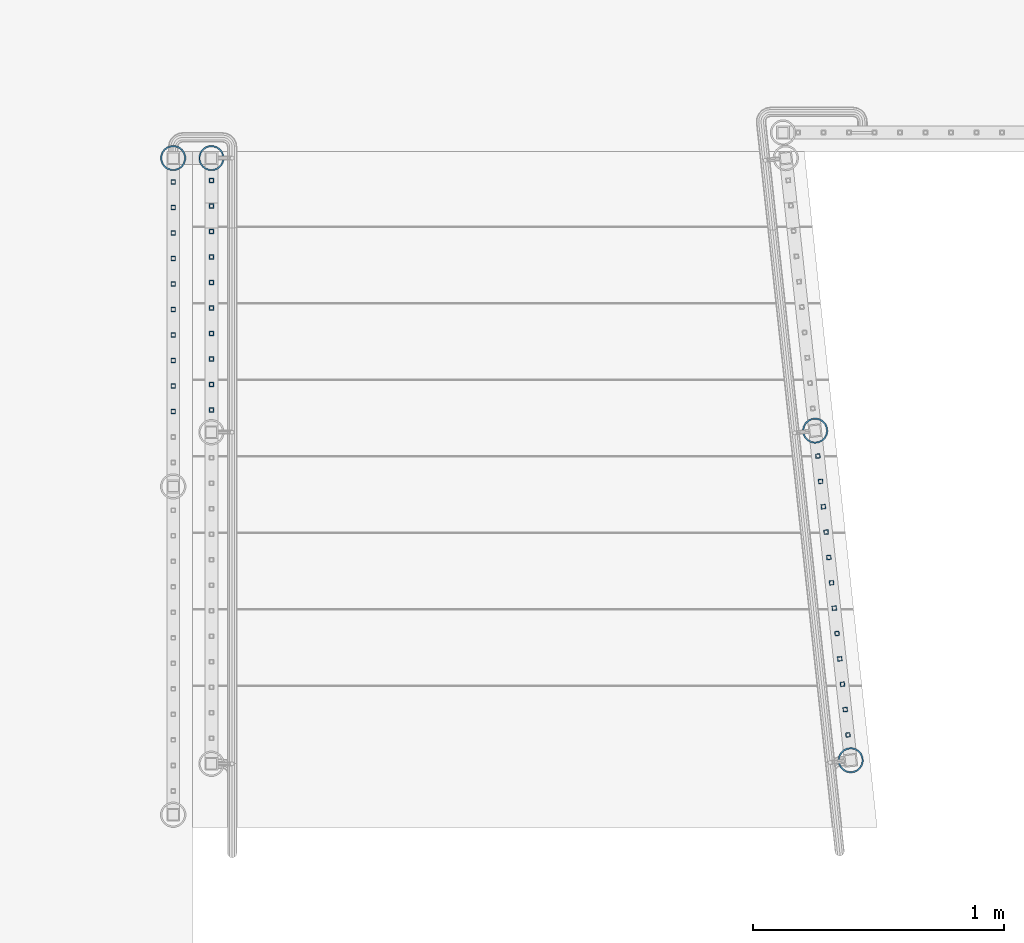
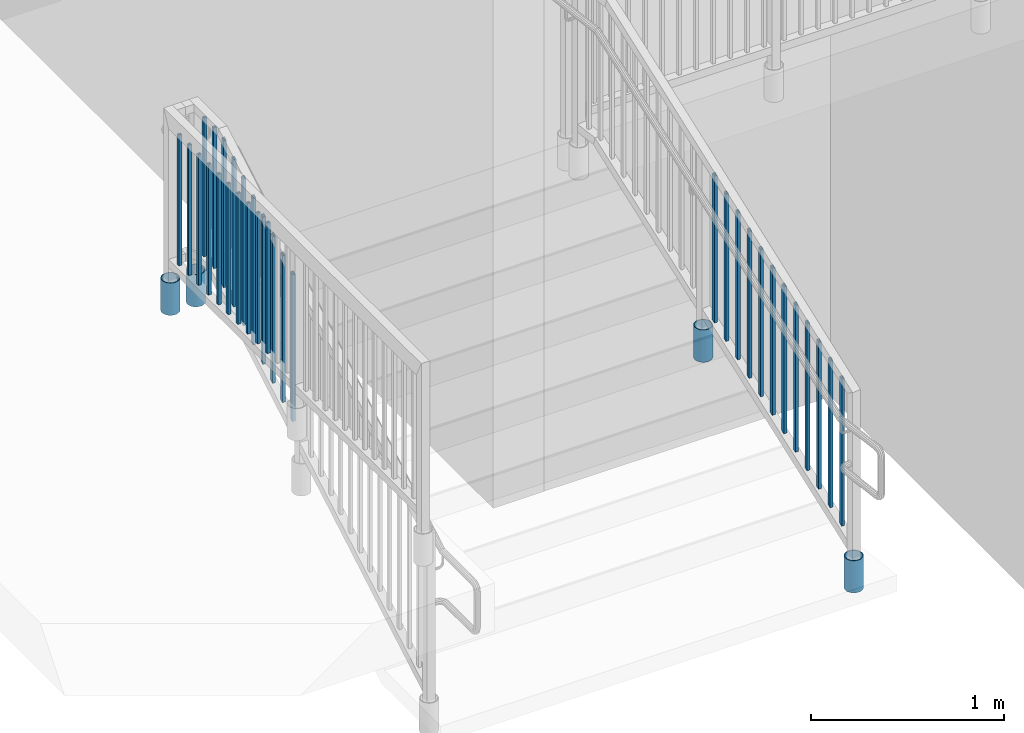
# One storey, part 141 of 975: 36 columns.
"""IFC2X3 building model written with IfcOpenShell, lengths in millimetres."""

import ifcopenshell
import ifcopenshell.guid

model = None  # the IFC model being written
_history = None  # IfcOwnerHistory: only IFC2X3 demands one
_inside = {}  # id of a spatial element -> (the spatial element, [elements in it])
_under = {}  # id of a project, library or spatial element -> (it, [spatial elements below it])
_declared = {}  # id of a project -> (the project, [libraries it declares])
_typed = {}  # id of a type object -> (the type object, [elements of that type])
_made_of = {}  # id of a material, layer set ... -> (it, [elements and type objects made of it])


def new_model(schema):
    """Start an empty IFC model of exactly this schema.

    Asked for "IFC4X3", IfcOpenShell would pick the latest addendum, in which some entities
    have other attributes; the version numbers below select the first issue.
    IFC2X3 requires an IfcOwnerHistory on every rooted entity: one is made here for all.
    """
    global model, _history
    if schema == "IFC4X3":
        model = ifcopenshell.file(schema_version=(4, 3, 0, 0))
    else:
        model = ifcopenshell.file(schema=schema)
    _inside.clear()
    _under.clear()
    _declared.clear()
    _typed.clear()
    _made_of.clear()
    _history = None
    if model.schema == "IFC2X3":
        org = make("IfcOrganization", Name="unknown")
        user = make(
            "IfcPersonAndOrganization",
            ThePerson=make("IfcPerson", FamilyName="unknown"),
            TheOrganization=org,
        )
        app = make(
            "IfcApplication",
            ApplicationDeveloper=org,
            Version="unknown",
            ApplicationFullName="unknown",
            ApplicationIdentifier="unknown",
        )
        _history = make(
            "IfcOwnerHistory",
            OwningUser=user,
            OwningApplication=app,
            ChangeAction="ADDED",
            CreationDate=0,
        )
    return model


def make(cls, **values):
    """One entity of the class cls with the attributes given. An attribute that is None is left unset."""
    return model.create_entity(
        cls, **{name: value for name, value in values.items() if value is not None}
    )


def rooted(cls, **values):
    """An entity with a GlobalId (a new one), such as an element, a storey or a relation."""
    return make(cls, GlobalId=ifcopenshell.guid.new(), OwnerHistory=_history, **values)


def si_unit(unit_type, name, prefix=None):
    """IfcSIUnit, for example si_unit("LENGTHUNIT", "METRE", prefix="MILLI")."""
    return make("IfcSIUnit", UnitType=unit_type, Prefix=prefix, Name=name)


def assignment(units):
    """IfcUnitAssignment: the units of a project."""
    return None if units is None else make("IfcUnitAssignment", Units=units)


def point(xyz):
    """IfcCartesianPoint."""
    return None if xyz is None else make("IfcCartesianPoint", Coordinates=xyz)


def direction(xyz):
    """IfcDirection."""
    return None if xyz is None else make("IfcDirection", DirectionRatios=xyz)


def frame(location, z_axis=None, x_axis=None):
    """IfcAxis2Placement3D, a coordinate frame: its origin and axes. An axis left out is left unset."""
    return make(
        "IfcAxis2Placement3D",
        Location=point(location),
        Axis=direction(z_axis),
        RefDirection=direction(x_axis),
    )


def origin_with_axes():
    """The frame at (0, 0, 0) with the z axis (0, 0, 1) and the x axis (1, 0, 0) written out."""
    return frame((0.0, 0.0, 0.0), z_axis=(0.0, 0.0, 1.0), x_axis=(1.0, 0.0, 0.0))


def place(relative_to, where):
    """IfcLocalPlacement: puts the frame where relative to a parent placement (None: the world)."""
    return make(
        "IfcLocalPlacement", PlacementRelTo=relative_to, RelativePlacement=where
    )


def context(
    kind, dimensions, precision=None, world=None, true_north=None, identifier=None
):
    """IfcGeometricRepresentationContext, for example the 3D "Model" context."""
    return make(
        "IfcGeometricRepresentationContext",
        ContextIdentifier=identifier,
        ContextType=kind,
        CoordinateSpaceDimension=dimensions,
        Precision=precision,
        WorldCoordinateSystem=world,
        TrueNorth=true_north,
    )


def subcontext(parent, identifier, kind, view, scale=None):
    """IfcGeometricRepresentationSubContext, for example "Body" below "Model"."""
    return make(
        "IfcGeometricRepresentationSubContext",
        ContextIdentifier=identifier,
        ContextType=kind,
        ParentContext=parent,
        TargetScale=scale,
        TargetView=view,
    )


def project(units=None, contexts=None):
    """IfcProject with its units and contexts."""
    return rooted(
        "IfcProject",
        Name="project",
        RepresentationContexts=contexts,
        UnitsInContext=assignment(units),
    )


def spatial(cls, under=None, at=None, **own):
    """A site, building, storey or space (cls), placed at a placement, below another one or the project."""
    s = rooted(cls, ObjectPlacement=at, **own)
    if under is not None:
        _under.setdefault(under.id(), (under, []))[1].append(s)
    return s


def faces_of(points, faces, orient=None, outer=None):
    """IfcFace entities. A face is a list of loops; a loop is a list of indices into points, from 0.

    orient and outer hold one flag for each loop. By default every Orientation is true, the
    first loop of a face is its IfcFaceOuterBound and the others are IfcFaceBound.
    """
    made = []
    for i, loops in enumerate(faces):
        bounds = []
        for j, loop in enumerate(loops):
            is_outer = j == 0 if outer is None else outer[i][j]
            bounds.append(
                make(
                    "IfcFaceOuterBound" if is_outer else "IfcFaceBound",
                    Bound=make("IfcPolyLoop", Polygon=[points[k] for k in loop]),
                    Orientation=True if orient is None else orient[i][j],
                )
            )
        made.append(make("IfcFace", Bounds=bounds))
    return made


def faceted_brep(points, faces, orient=None, outer=None, voids=None):
    """IfcFacetedBrep: a solid bounded by flat faces; with voids (closed shells), ...WithVoids."""
    shared = [point(p) for p in points]
    hull = make("IfcClosedShell", CfsFaces=faces_of(shared, faces, orient, outer))
    if voids is None:
        return make("IfcFacetedBrep", Outer=hull)
    return make(
        "IfcFacetedBrepWithVoids",
        Outer=hull,
        Voids=[
            make(cls, CfsFaces=faces_of(shared, fs, o, b)) for cls, fs, o, b in voids
        ],
    )


def shape(context_of_items, identifier, shape_type, items):
    """IfcShapeRepresentation: the items that make up one representation, for example the "Body"."""
    return make(
        "IfcShapeRepresentation",
        ContextOfItems=context_of_items,
        RepresentationIdentifier=identifier,
        RepresentationType=shape_type,
        Items=items,
    )


def material(Name=None, Category=None):
    """IfcMaterial."""
    return make("IfcMaterial", Name=Name, Category=Category)


def made_of(thing, what):
    """Note that an element or type object is made of a material, layer set ...; save() writes the relation."""
    if what is not None:
        _made_of.setdefault(what.id(), (what, []))[1].append(thing)
    return thing


def type_object(cls, material=None, **own):
    """A type object (cls), such as IfcWallType, which elements share."""
    return made_of(rooted(cls, **own), material)


def element(
    cls,
    number,
    at=None,
    inside=None,
    cuts=None,
    type_object=None,
    material=None,
    context=None,
    identifier="Body",
    shape_type=None,
    held_by="IfcProductDefinitionShape",
    body=None,
    shapes=None,
    **own,
):
    """One element of the class cls, such as IfcWall. Its Tag is "e" and its number.

    at: its placement. inside: the storey or other place that contains it. cuts: it is an
    opening in that element (IfcRelVoidsElement). A single representation is given by context,
    identifier, shape_type and body (its items); several are given by shapes. held_by: the class
    of the entity that holds the representations. save() writes the other relations.
    """
    e = rooted(cls, Tag="e%d" % number, ObjectPlacement=at, **own)
    if body is not None:
        shapes = [shape(context, identifier, shape_type, body)]
    if shapes is not None:
        e.Representation = make(held_by, Representations=shapes)
    if inside is not None:
        _inside.setdefault(inside.id(), (inside, []))[1].append(e)
    if cuts is not None:
        rooted(
            "IfcRelVoidsElement", RelatingBuildingElement=cuts, RelatedOpeningElement=e
        )
    if type_object is not None:
        _typed.setdefault(type_object.id(), (type_object, []))[1].append(e)
    return made_of(e, material)


def aggregate(whole, parts):
    """IfcRelAggregates: a whole, such as a stair, and the parts it consists of."""
    return rooted("IfcRelAggregates", RelatingObject=whole, RelatedObjects=parts)


def save(model, path):
    """Write the relations noted so far, then the file.

    IfcRelAggregates (storeys below a building ...), IfcRelContainedInSpatialStructure (elements
    in a storey), IfcRelDefinesByType, IfcRelAssociatesMaterial and IfcRelDeclares: one each for
    every whole, place, type object, material and project.
    """
    for whole, parts in _under.values():
        aggregate(whole, parts)
    for where, things in _inside.values():
        rooted(
            "IfcRelContainedInSpatialStructure",
            RelatedElements=things,
            RelatingStructure=where,
        )
    for kind, things in _typed.values():
        rooted("IfcRelDefinesByType", RelatedObjects=things, RelatingType=kind)
    for what, things in _made_of.values():
        rooted("IfcRelAssociatesMaterial", RelatedObjects=things, RelatingMaterial=what)
    for by, libraries in _declared.values():
        rooted("IfcRelDeclares", RelatingContext=by, RelatedDefinitions=libraries)
    model.write(path)


model = new_model("IFC2X3")

# Units and contexts
model_context = context("Model", 3, precision=1e-05, world=origin_with_axes())
body_context = subcontext(model_context, "Body", "Model", "MODEL_VIEW")
ifc_project = project(units=[si_unit("LENGTHUNIT", "METRE", prefix="MILLI"), si_unit("AREAUNIT", "SQUARE_METRE"), si_unit("VOLUMEUNIT", "CUBIC_METRE"), si_unit("MASSUNIT", "GRAM", prefix="KILO"), si_unit("TIMEUNIT", "SECOND"), si_unit("PLANEANGLEUNIT", "RADIAN"), si_unit("SOLIDANGLEUNIT", "STERADIAN"), si_unit("THERMODYNAMICTEMPERATUREUNIT", "DEGREE_CELSIUS"), si_unit("LUMINOUSINTENSITYUNIT", "LUMEN")], contexts=[model_context])

# Site, building, storey
site_placement = place(None, origin_with_axes())
site = spatial("IfcSite", under=ifc_project, at=site_placement, CompositionType="ELEMENT")
building_placement = place(site_placement, origin_with_axes())
building = spatial("IfcBuilding", under=site, at=building_placement, Name="Undefined", CompositionType="ELEMENT")
storey_placement = place(building_placement, origin_with_axes())
storey = spatial("IfcBuildingStorey", under=building, at=storey_placement, Name="Undefined", CompositionType="ELEMENT", Elevation=0.0)

# Columns
ifc_material_1 = material()
column_type_1 = type_object("IfcColumnType", Name="HSS3/4X3/4X.120_TUBES", PredefinedType="NOTDEFINED")
column_1_placement = place(storey_placement, frame((-3190.87499856836, 3136.90035321558, 4203.33691026911), z_axis=(0.0, 1.0, 0.0), x_axis=(0.0, 0.0, 1.0)))
element("IfcColumn", 1, at=column_1_placement, inside=storey, type_object=column_type_1, material=ifc_material_1, Name="PICKET", ObjectType="HSS3/4X3/4X.120_TUBES", context=body_context, shape_type="Brep", body=[
    faceted_brep([(51.1631046552238, 6.34999999999991, -6.35000000000855), (51.1631046600623, -6.34999999999991, -6.35000000000855), (927.463079106175, -6.34999999999991, -6.3500000001477), (927.463079101335, 6.34999999999991, -6.3500000001477), (51.1630993403815, -6.34999999999991, 6.34999999999172), (927.463078498194, -6.34999999999991, 6.34999999985257), (51.1630993355429, 6.34999999999991, 6.34999999999172), (927.463078493354, 6.34999999999991, 6.34999999985257), (51.1631059839347, 9.52500000000009, -9.52500000000873), (51.1630980044138, 9.52500000000009, 9.52499999999191), (927.463078340149, 9.52500000000009, 9.5249999998523), (927.46307925212, 9.52500000000009, -9.52500000014743), (51.1630980116715, -9.52500000000009, 9.52499999999191), (927.463078347408, -9.52500000000009, 9.5249999998523), (51.1631059911924, -9.52500000000009, -9.52500000000873), (927.463079259379, -9.52500000000009, -9.52500000014743)], [[[0, 1, 2, 3]], [[1, 4, 5, 2]], [[4, 6, 7, 5]], [[6, 0, 3, 7]], [[8, 9, 10, 11]], [[9, 12, 13, 10]], [[12, 14, 15, 13]], [[14, 8, 11, 15]], [[13, 15, 11, 10], [5, 7, 3, 2]], [[14, 12, 9, 8], [6, 4, 1, 0]]]),
])
column_2_placement = place(storey_placement, frame((-3190.87499856836, 3035.30035321558, 4203.33691026911), z_axis=(0.0, 1.0, 0.0), x_axis=(0.0, 0.0, 1.0)))
element("IfcColumn", 2, at=column_2_placement, inside=storey, type_object=column_type_1, material=ifc_material_1, Name="PICKET", ObjectType="HSS3/4X3/4X.120_TUBES", context=body_context, shape_type="Brep", body=[
    faceted_brep([(40.1428276989536, 6.34999999999991, -6.35000000000673), (40.1428276989536, -6.34999999999991, -6.35000000000673), (927.463079106175, -6.34999999999991, -6.3500000001477), (927.463079101335, 6.34999999999991, -6.3500000001477), (47.5511612937316, -6.34999999999991, 6.34999999999218), (927.463078498194, -6.34999999999991, 6.34999999985257), (47.5511612937316, 6.34999999999991, 6.34999999999218), (927.463078493354, 6.34999999999991, 6.34999999985257), (38.2907443002596, 9.52500000000009, -9.52500000000646), (49.4032446924266, 9.52500000000009, 9.52499999999191), (927.463078340149, 9.52500000000009, 9.5249999998523), (927.46307925212, 9.52500000000009, -9.52500000014743), (49.4032446924266, -9.52500000000009, 9.52499999999191), (927.463078347408, -9.52500000000009, 9.5249999998523), (38.2907443002596, -9.52500000000009, -9.52500000000646), (927.463079259379, -9.52500000000009, -9.52500000014743)], [[[0, 1, 2, 3]], [[1, 4, 5, 2]], [[4, 6, 7, 5]], [[6, 0, 3, 7]], [[8, 9, 10, 11]], [[9, 12, 13, 10]], [[12, 14, 15, 13]], [[14, 8, 11, 15]], [[13, 15, 11, 10], [5, 7, 3, 2]], [[14, 12, 9, 8], [6, 4, 1, 0]]]),
])
for number, where, z_axis, x_axis, name in (
    (3, (-3190.87499856836, 2933.70035321558, 4187.9172376658), (0.0, 1.0, 0.0), (0.0, 0.0, 1.0), "PICKET"),
    (4, (-3190.87499856836, 2832.10035321558, 4128.65057095013), (0.0, 1.0, 0.0), (0.0, 0.0, 1.0), "PICKET"),
    (5, (-3190.87499856836, 2730.50035321516, 4069.38390423445), (0.0, 1.0, 0.0), (0.0, 0.0, 1.0), "PICKET"),
    (6, (-3190.87499856836, 2628.90035321516, 4010.11723751877), (0.0, 1.0, 0.0), (0.0, 0.0, 1.0), "PICKET"),
    (7, (-3190.87499856836, 2527.30035321516, 3950.8505708031), (0.0, 1.0, 0.0), (0.0, 0.0, 1.0), "PICKET"),
    (8, (-3190.87499856836, 2425.70035321516, 3891.58390408742), (0.0, 1.0, 0.0), (0.0, 0.0, 1.0), "PICKET"),
    (9, (-3190.87499856836, 2324.10035321516, 3832.31723737174), (0.0, 1.0, 0.0), (0.0, 0.0, 1.0), "PICKET"),
    (10, (-3190.87499856836, 2222.50035321516, 3773.05057065607), (0.0, 1.0, 0.0), (0.0, 0.0, 1.0), "PICKET"),
    (11, (-774.63710304161, 2038.78708413502, 3661.87399893735), (-0.107163682972125, 0.994241391741387, -1.51279482452082e-08), (0.0, 0.0, 1.0), "PICKET"),
    (12, (-763.750059341861, 1937.77948397427, 3602.61162984238), (-0.107163682972125, 0.994241391741387, -1.51279482452082e-08), (0.0, 0.0, 1.0), "PICKET"),
    (13, (-752.863015642112, 1836.77188381352, 3543.3492607474), (-0.107163682972125, 0.994241391741387, -1.51279482452082e-08), (0.0, 0.0, 1.0), "PICKET"),
    (14, (-741.975971942363, 1735.76428365277, 3484.08689165243), (-0.107163682972125, 0.994241391741387, -1.51279482452082e-08), (0.0, 0.0, 1.0), "PICKET"),
    (15, (-731.088928242615, 1634.75668349202, 3424.82452255745), (-0.107163682972125, 0.994241391741387, -1.51279482452082e-08), (0.0, 0.0, 1.0), "PICKET"),
    (16, (-720.201884542866, 1533.74908333127, 3365.56215346248), (-0.107163682972125, 0.994241391741387, -1.51279482452082e-08), (0.0, 0.0, 1.0), "PICKET"),
    (17, (-709.314840843117, 1432.74148317052, 3306.2997843675), (-0.107163682972125, 0.994241391741387, -1.51279482452082e-08), (0.0, 0.0, 1.0), "PICKET"),
    (18, (-698.427797143368, 1331.73388300977, 3247.03741527253), (-0.107163682972125, 0.994241391741387, -1.51279482452082e-08), (0.0, 0.0, 1.0), "PICKET"),
    (19, (-687.540753443619, 1230.72628284902, 3187.77504617756), (-0.107163682972125, 0.994241391741387, -1.51279482452082e-08), (0.0, 0.0, 1.0), "PICKET"),
    (20, (-676.65370974387, 1129.71868268827, 3128.51267708258), (-0.107163682972125, 0.994241391741387, -1.51279482452082e-08), (0.0, 0.0, 1.0), "PICKET"),
    (21, (-665.766666044122, 1028.71108252753, 3069.25030798761), (-0.107163682972125, 0.994241391741387, -1.51279482452082e-08), (0.0, 0.0, 1.0), "PICKET"),
    (22, (-654.879622344373, 927.70348236678, 3009.98793889263), (-0.107163682972125, 0.994241391741387, -1.51279482452082e-08), (0.0, 0.0, 1.0), "PICKET"),
):
    element("IfcColumn", number, at=place(storey_placement, frame(where, z_axis=z_axis, x_axis=x_axis)), inside=storey, type_object=column_type_1, material=ifc_material_1, Name=name, ObjectType="HSS3/4X3/4X.120_TUBES", context=body_context, shape_type="Brep", body=[
        faceted_brep([(-3.70416645998739, 6.34999999999991, -6.34999999999945), (-3.70416623769415, -6.34999999999991, -6.34999999999945), (923.75891709344, -6.34999999999991, -6.35000000014634), (923.758916871147, 6.34999999999991, -6.35000000014634), (3.70416736539664, -6.34999999999991, 6.349999999999), (931.167250696531, -6.34999999999991, 6.34999999985212), (3.70416714310431, 6.34999999999991, 6.349999999999), (931.167250474238, 6.34999999999991, 6.34999999985212), (-5.5562499163334, 9.52500000000009, -9.52499999999964), (5.5562504883037, 9.52500000000009, 9.52499999999918), (933.019333819438, 9.52500000000009, 9.5249999998523), (921.906833414801, 9.52500000000009, -9.52500000014652), (5.55625082174265, -9.52500000000009, 9.52499999999918), (933.019334152877, -9.52500000000009, 9.5249999998523), (-5.55624958289354, -9.52500000000009, -9.52499999999964), (921.90683374824, -9.52500000000009, -9.52500000014652)], [[[0, 1, 2, 3]], [[1, 4, 5, 2]], [[4, 6, 7, 5]], [[6, 0, 3, 7]], [[8, 9, 10, 11]], [[9, 12, 13, 10]], [[12, 14, 15, 13]], [[14, 8, 11, 15]], [[13, 15, 11, 10], [5, 7, 3, 2]], [[14, 12, 9, 8], [6, 4, 1, 0]]]),
    ])
for number, where, z_axis, x_axis, name in (
    (23, (-3343.27499858123, 3130.55033997135, 4254.50002289519), (0.0, 1.0, 0.0), (0.0, 0.0, 1.0), "PICKET"),
    (24, (-3343.27499858123, 3028.95033997135, 4254.50002289519), (0.0, 1.0, 0.0), (0.0, 0.0, 1.0), "PICKET"),
    (25, (-3343.27499858123, 2927.35033997135, 4254.50002289519), (0.0, 1.0, 0.0), (0.0, 0.0, 1.0), "PICKET"),
    (26, (-3343.27499858123, 2825.75033997135, 4254.50002289519), (0.0, 1.0, 0.0), (0.0, 0.0, 1.0), "PICKET"),
    (27, (-3343.27499858123, 2724.15033997135, 4254.50002289519), (0.0, 1.0, 0.0), (0.0, 0.0, 1.0), "PICKET"),
    (28, (-3343.27499858123, 2622.55033997135, 4254.50002289519), (0.0, 1.0, 0.0), (0.0, 0.0, 1.0), "PICKET"),
    (29, (-3343.27499858123, 2520.95033997135, 4254.50002289519), (0.0, 1.0, 0.0), (0.0, 0.0, 1.0), "PICKET"),
    (30, (-3343.27499858123, 2419.35033997135, 4254.50002289519), (0.0, 1.0, 0.0), (0.0, 0.0, 1.0), "PICKET"),
    (31, (-3343.27499858123, 2317.75033997135, 4254.50002289519), (0.0, 1.0, 0.0), (0.0, 0.0, 1.0), "PICKET"),
    (32, (-3343.27499858123, 2216.15033997135, 4254.50002289519), (0.0, 1.0, 0.0), (0.0, 0.0, 1.0), "PICKET"),
):
    element("IfcColumn", number, at=place(storey_placement, frame(where, z_axis=z_axis, x_axis=x_axis)), inside=storey, type_object=column_type_1, material=ifc_material_1, Name=name, ObjectType="HSS3/4X3/4X.120_TUBES", context=body_context, shape_type="Brep", body=[
        faceted_brep([(0.0, 6.34999999998763, -6.34999999998763), (0.0, -6.35000000000582, -6.34999999998763), (825.49997943247, -6.35000000000582, -6.34999999998763), (825.49997943247, 6.34999999998763, -6.34999999998763), (0.0, -6.34999999998763, 6.34999999998763), (825.49997943247, -6.34999999998763, 6.34999999998763), (0.0, 6.35000000000946, 6.34999999998763), (825.49997943247, 6.35000000000946, 6.34999999998763), (0.0, 9.52499999997963, -9.52499999997963), (0.0, 9.52500000000873, 9.5249999999869), (825.49997943247, 9.52500000000873, 9.5249999999869), (825.49997943247, 9.52499999997963, -9.52499999997963), (0.0, -9.52499999997963, 9.52499999998327), (825.49997943247, -9.52499999997963, 9.52499999998327), (0.0, -9.52500000000873, -9.5249999999869), (825.49997943247, -9.52500000000873, -9.5249999999869)], [[[0, 1, 2, 3]], [[1, 4, 5, 2]], [[4, 6, 7, 5]], [[6, 0, 3, 7]], [[8, 9, 10, 11]], [[9, 12, 13, 10]], [[12, 14, 15, 13]], [[14, 8, 11, 15]], [[13, 15, 11, 10], [5, 7, 3, 2]], [[14, 12, 9, 8], [6, 4, 1, 0]]]),
    ])
ifc_material_2 = material(Name="STEEL/A53")
column_type_2 = type_object("IfcColumnType", Name="PIPE3-1/2STD", PredefinedType="NOTDEFINED")
column_3_placement = place(storey_placement, frame((-785.534411542738, 2139.88991820161, 3378.20002478374), z_axis=(-0.778811015080024, 0.627258641064452, -9.08472520677606e-09), x_axis=(0.0, 0.0, 1.0)))
element("IfcColumn", 33, at=column_3_placement, inside=storey, type_object=column_type_2, material=ifc_material_2, ObjectType="PIPE3-1/2STD", context=body_context, shape_type="Brep", body=[
    faceted_brep([(0.0, -45.0595999999932, 1.45519152283669e-11), (0.0, -42.8542262016344, 13.924182159768), (203.199999999991, -42.8542262017145, 13.9241821598171), (203.19999999999, -45.0596000000478, 5.82076609134674e-11), (0.0, -36.45398215971, 26.4853683542424), (203.199999999993, -36.45398215981, 26.4853683542988), (0.0, -26.4853683541623, 36.45398215979), (203.199999999995, -26.4853683542788, 36.4539821598537), (0.0, -13.9241821596988, 42.8542262017108), (203.199999999998, -13.9241821598262, 42.8542262017836), (0.0, 3.63797880709171e-11, 45.0596000000514), (203.2, -9.27684595808387e-11, 45.0596000001387), (0.0, 13.9241821597716, 42.8542262017036), (203.200000000003, 13.9241821596443, 42.8542262017927), (0.0, 26.4853683542242, 36.4539821597718), (203.200000000006, 26.4853683541096, 36.4539821598701), (0.0, 36.4539821597537, 26.4853683542206), (203.200000000008, 36.4539821596554, 26.4853683543224), (0.0, 42.8542262016563, 13.9241821597425), (203.200000000009, 42.8542262015817, 13.9241821598443), (0.0, 45.0595999999932, -1.09139364212751e-11), (203.200000000009, 45.0595999999423, 8.9130480773747e-11), (0.0, 42.8542262016344, -13.9241821597643), (203.200000000008, 42.854226201609, -13.9241821596697), (0.0, 36.45398215971, -26.4853683542387), (203.200000000007, 36.4539821597045, -26.4853683541514), (0.0, 26.4853683541623, -36.4539821597864), (203.200000000004, 26.4853683541733, -36.4539821597064), (0.0, 13.9241821596988, -42.8542262017072), (203.200000000002, 13.9241821597225, -42.8542262016381), (0.0, -3.63797880709171e-11, -45.0596000000478), (203.199999999999, -9.09494701772928e-12, -45.0595999999914), (0.0, -13.9241821597716, -42.8542262016963), (203.199999999996, -13.9241821597479, -42.8542262016472), (0.0, -26.4853683542242, -36.4539821597682), (203.199999999993, -26.4853683542133, -36.4539821597227), (0.0, -36.4539821597537, -26.4853683542169), (203.199999999992, -36.4539821597609, -26.4853683541751), (0.0, -42.8542262016563, -13.9241821597352), (203.199999999991, -42.8542262016872, -13.924182159697), (0.0, -50.799999999992, 1.81898940354586e-11), (0.0, -48.3136710278013, -15.6980633142484), (203.199999999989, -48.313671027825, -15.6980633142139), (203.199999999989, -50.8000000000466, 5.63886715099216e-11), (0.0, -41.0980633142644, -29.8594908164741), (203.19999999999, -41.0980633142663, -29.8594908164414), (0.0, -29.859490816485, -41.0980633142826), (203.199999999993, -29.8594908164687, -41.0980633142426), (0.0, -15.6980633142848, -48.313671027845), (203.199999999995, -15.6980633142539, -48.313671027794), (0.0, -4.36557456851006e-11, -50.8000000000575), (203.199999999998, -7.27595761418343e-12, -50.7999999999993), (0.0, 15.6980633142011, -48.3136710278523), (203.200000000002, 15.6980633142375, -48.3136710277831), (0.0, 29.8594908164159, -41.0980633143045), (203.200000000005, 29.8594908164378, -41.0980633142226), (0.0, 41.0980633142135, -29.8594908165032), (203.200000000008, 41.0980633142171, -29.8594908164141), (0.0, 48.3136710277722, -15.6980633142775), (203.200000000009, 48.3136710277504, -15.6980633141811), (0.0, 50.799999999992, -1.45519152283669e-11), (203.20000000001, 50.7999999999411, 9.09494701772928e-11), (0.0, 48.313671027794, 15.6980633142521), (203.20000000001, 48.3136710277213, 15.6980633143594), (0.0, 41.0980633142644, 29.8594908164814), (203.200000000008, 41.0980633141626, 29.8594908165887), (0.0, 29.859490816485, 41.0980633142863), (203.200000000007, 29.8594908163632, 41.0980633143899), (0.0, 15.6980633142848, 48.3136710278486), (203.200000000004, 15.6980633141484, 48.3136710279414), (0.0, 4.00177668780088e-11, 50.8000000000611), (203.200000000001, -9.82254277914762e-11, 50.8000000001466), (0.0, -15.6980633142011, 48.3136710278559), (203.199999999997, -15.698063314343, 48.3136710279305), (0.0, -29.8594908164159, 41.0980633143081), (203.199999999994, -29.8594908165433, 41.0980633143681), (0.0, -41.0980633142171, 29.8594908165069), (203.199999999992, -41.0980633143226, 29.8594908165596), (0.0, -48.3136710277722, 15.6980633142812), (203.19999999999, -48.3136710278559, 15.6980633143285)], [[[0, 1, 2, 3]], [[1, 4, 5, 2]], [[4, 6, 7, 5]], [[6, 8, 9, 7]], [[8, 10, 11, 9]], [[10, 12, 13, 11]], [[12, 14, 15, 13]], [[14, 16, 17, 15]], [[16, 18, 19, 17]], [[18, 20, 21, 19]], [[20, 22, 23, 21]], [[22, 24, 25, 23]], [[24, 26, 27, 25]], [[26, 28, 29, 27]], [[28, 30, 31, 29]], [[30, 32, 33, 31]], [[32, 34, 35, 33]], [[34, 36, 37, 35]], [[36, 38, 39, 37]], [[38, 0, 3, 39]], [[40, 41, 42, 43]], [[41, 44, 45, 42]], [[44, 46, 47, 45]], [[46, 48, 49, 47]], [[48, 50, 51, 49]], [[50, 52, 53, 51]], [[52, 54, 55, 53]], [[54, 56, 57, 55]], [[56, 58, 59, 57]], [[58, 60, 61, 59]], [[60, 62, 63, 61]], [[62, 64, 65, 63]], [[64, 66, 67, 65]], [[66, 68, 69, 67]], [[68, 70, 71, 69]], [[70, 72, 73, 71]], [[72, 74, 75, 73]], [[74, 76, 77, 75]], [[76, 78, 79, 77]], [[78, 40, 43, 79]], [[45, 47, 49, 51, 53, 55, 57, 59, 61, 63, 65, 67, 69, 71, 73, 75, 77, 79, 43, 42], [5, 7, 9, 11, 13, 15, 17, 19, 21, 23, 25, 27, 29, 31, 33, 35, 37, 39, 3, 2]], [[78, 76, 74, 72, 70, 68, 66, 64, 62, 60, 58, 56, 54, 52, 50, 48, 46, 44, 41, 40], [38, 36, 34, 32, 30, 28, 26, 24, 22, 20, 18, 16, 14, 12, 10, 8, 6, 4, 1, 0]]]),
])
column_4_placement = place(storey_placement, frame((-643.992578658733, 826.6958816702, 2666.99998821452), z_axis=(-0.778811015080024, 0.627258641064452, -9.08472520677606e-09), x_axis=(0.0, 0.0, 1.0)))
element("IfcColumn", 34, at=column_4_placement, inside=storey, type_object=column_type_2, material=ifc_material_2, ObjectType="PIPE3-1/2STD", context=body_context, shape_type="Brep", body=[
    faceted_brep([(0.0, -45.0595999999932, 1.45519152283669e-11), (0.0, -42.8542262016344, 13.924182159768), (203.199999999991, -42.8542262017145, 13.9241821598171), (203.19999999999, -45.0596000000478, 5.82076609134674e-11), (0.0, -36.45398215971, 26.4853683542424), (203.199999999993, -36.45398215981, 26.4853683542988), (0.0, -26.4853683541623, 36.45398215979), (203.199999999995, -26.4853683542788, 36.4539821598537), (0.0, -13.9241821596988, 42.8542262017108), (203.199999999998, -13.9241821598262, 42.8542262017836), (0.0, 3.63797880709171e-11, 45.0596000000514), (203.2, -9.27684595808387e-11, 45.0596000001387), (0.0, 13.9241821597716, 42.8542262017036), (203.200000000003, 13.9241821596443, 42.8542262017927), (0.0, 26.4853683542242, 36.4539821597718), (203.200000000006, 26.4853683541096, 36.4539821598701), (0.0, 36.4539821597537, 26.4853683542206), (203.200000000008, 36.4539821596554, 26.4853683543224), (0.0, 42.8542262016563, 13.9241821597425), (203.200000000009, 42.8542262015817, 13.9241821598443), (0.0, 45.0595999999932, -1.09139364212751e-11), (203.200000000009, 45.0595999999423, 8.9130480773747e-11), (0.0, 42.8542262016344, -13.9241821597643), (203.200000000008, 42.854226201609, -13.9241821596697), (0.0, 36.45398215971, -26.4853683542387), (203.200000000007, 36.4539821597045, -26.4853683541514), (0.0, 26.4853683541623, -36.4539821597864), (203.200000000004, 26.4853683541733, -36.4539821597064), (0.0, 13.9241821596988, -42.8542262017072), (203.200000000002, 13.9241821597225, -42.8542262016381), (0.0, -3.63797880709171e-11, -45.0596000000478), (203.199999999999, -9.09494701772928e-12, -45.0595999999914), (0.0, -13.9241821597716, -42.8542262016963), (203.199999999996, -13.9241821597479, -42.8542262016472), (0.0, -26.4853683542242, -36.4539821597682), (203.199999999993, -26.4853683542133, -36.4539821597227), (0.0, -36.4539821597537, -26.4853683542169), (203.199999999992, -36.4539821597609, -26.4853683541751), (0.0, -42.8542262016563, -13.9241821597352), (203.199999999991, -42.8542262016872, -13.924182159697), (0.0, -50.799999999992, 1.81898940354586e-11), (0.0, -48.3136710278013, -15.6980633142484), (203.199999999989, -48.313671027825, -15.6980633142139), (203.199999999989, -50.8000000000466, 5.63886715099216e-11), (0.0, -41.0980633142644, -29.8594908164741), (203.19999999999, -41.0980633142663, -29.8594908164414), (0.0, -29.859490816485, -41.0980633142826), (203.199999999993, -29.8594908164687, -41.0980633142426), (0.0, -15.6980633142848, -48.313671027845), (203.199999999995, -15.6980633142539, -48.313671027794), (0.0, -4.36557456851006e-11, -50.8000000000575), (203.199999999998, -7.27595761418343e-12, -50.7999999999993), (0.0, 15.6980633142011, -48.3136710278523), (203.200000000002, 15.6980633142375, -48.3136710277831), (0.0, 29.8594908164159, -41.0980633143045), (203.200000000005, 29.8594908164378, -41.0980633142226), (0.0, 41.0980633142135, -29.8594908165032), (203.200000000008, 41.0980633142171, -29.8594908164141), (0.0, 48.3136710277722, -15.6980633142775), (203.200000000009, 48.3136710277504, -15.6980633141811), (0.0, 50.799999999992, -1.45519152283669e-11), (203.20000000001, 50.7999999999411, 9.09494701772928e-11), (0.0, 48.313671027794, 15.6980633142521), (203.20000000001, 48.3136710277213, 15.6980633143594), (0.0, 41.0980633142644, 29.8594908164814), (203.200000000008, 41.0980633141626, 29.8594908165887), (0.0, 29.859490816485, 41.0980633142863), (203.200000000007, 29.8594908163632, 41.0980633143899), (0.0, 15.6980633142848, 48.3136710278486), (203.200000000004, 15.6980633141484, 48.3136710279414), (0.0, 4.00177668780088e-11, 50.8000000000611), (203.200000000001, -9.82254277914762e-11, 50.8000000001466), (0.0, -15.6980633142011, 48.3136710278559), (203.199999999997, -15.698063314343, 48.3136710279305), (0.0, -29.8594908164159, 41.0980633143081), (203.199999999994, -29.8594908165433, 41.0980633143681), (0.0, -41.0980633142171, 29.8594908165069), (203.199999999992, -41.0980633143226, 29.8594908165596), (0.0, -48.3136710277722, 15.6980633142812), (203.19999999999, -48.3136710278559, 15.6980633143285)], [[[0, 1, 2, 3]], [[1, 4, 5, 2]], [[4, 6, 7, 5]], [[6, 8, 9, 7]], [[8, 10, 11, 9]], [[10, 12, 13, 11]], [[12, 14, 15, 13]], [[14, 16, 17, 15]], [[16, 18, 19, 17]], [[18, 20, 21, 19]], [[20, 22, 23, 21]], [[22, 24, 25, 23]], [[24, 26, 27, 25]], [[26, 28, 29, 27]], [[28, 30, 31, 29]], [[30, 32, 33, 31]], [[32, 34, 35, 33]], [[34, 36, 37, 35]], [[36, 38, 39, 37]], [[38, 0, 3, 39]], [[40, 41, 42, 43]], [[41, 44, 45, 42]], [[44, 46, 47, 45]], [[46, 48, 49, 47]], [[48, 50, 51, 49]], [[50, 52, 53, 51]], [[52, 54, 55, 53]], [[54, 56, 57, 55]], [[56, 58, 59, 57]], [[58, 60, 61, 59]], [[60, 62, 63, 61]], [[62, 64, 65, 63]], [[64, 66, 67, 65]], [[66, 68, 69, 67]], [[68, 70, 71, 69]], [[70, 72, 73, 71]], [[72, 74, 75, 73]], [[74, 76, 77, 75]], [[76, 78, 79, 77]], [[78, 40, 43, 79]], [[45, 47, 49, 51, 53, 55, 57, 59, 61, 63, 65, 67, 69, 71, 73, 75, 77, 79, 43, 42], [5, 7, 9, 11, 13, 15, 17, 19, 21, 23, 25, 27, 29, 31, 33, 35, 37, 39, 3, 2]], [[78, 76, 74, 72, 70, 68, 66, 64, 62, 60, 58, 56, 54, 52, 50, 48, 46, 44, 41, 40], [38, 36, 34, 32, 30, 28, 26, 24, 22, 20, 18, 16, 14, 12, 10, 8, 6, 4, 1, 0]]]),
])
column_5_placement = place(storey_placement, frame((-3343.2749985941, 3225.80035284919, 3911.60001649977), z_axis=(-0.707106781186601, 0.707106781186494, 2.36468622460961e-14), x_axis=(0.0, 0.0, 1.0)))
element("IfcColumn", 35, at=column_5_placement, inside=storey, type_object=column_type_2, material=ifc_material_2, ObjectType="PIPE3-1/2STD", context=body_context, shape_type="Brep", body=[
    faceted_brep([(0.0, -45.0595999999932, 1.45519152283669e-11), (0.0, -42.8542262016344, 13.924182159768), (203.199999999991, -42.8542262017145, 13.9241821598171), (203.19999999999, -45.0596000000478, 5.82076609134674e-11), (0.0, -36.45398215971, 26.4853683542424), (203.199999999993, -36.45398215981, 26.4853683542988), (0.0, -26.4853683541623, 36.45398215979), (203.199999999995, -26.4853683542788, 36.4539821598537), (0.0, -13.9241821596988, 42.8542262017108), (203.199999999998, -13.9241821598262, 42.8542262017836), (0.0, 3.63797880709171e-11, 45.0596000000514), (203.2, -9.27684595808387e-11, 45.0596000001387), (0.0, 13.9241821597716, 42.8542262017036), (203.200000000003, 13.9241821596443, 42.8542262017927), (0.0, 26.4853683542242, 36.4539821597718), (203.200000000006, 26.4853683541096, 36.4539821598701), (0.0, 36.4539821597537, 26.4853683542206), (203.200000000008, 36.4539821596554, 26.4853683543224), (0.0, 42.8542262016563, 13.9241821597425), (203.200000000009, 42.8542262015817, 13.9241821598443), (0.0, 45.0595999999932, -1.09139364212751e-11), (203.200000000009, 45.0595999999423, 8.9130480773747e-11), (0.0, 42.8542262016344, -13.9241821597643), (203.200000000008, 42.854226201609, -13.9241821596697), (0.0, 36.45398215971, -26.4853683542387), (203.200000000007, 36.4539821597045, -26.4853683541514), (0.0, 26.4853683541623, -36.4539821597864), (203.200000000004, 26.4853683541733, -36.4539821597064), (0.0, 13.9241821596988, -42.8542262017072), (203.200000000002, 13.9241821597225, -42.8542262016381), (0.0, -3.63797880709171e-11, -45.0596000000478), (203.199999999999, -9.09494701772928e-12, -45.0595999999914), (0.0, -13.9241821597716, -42.8542262016963), (203.199999999996, -13.9241821597479, -42.8542262016472), (0.0, -26.4853683542242, -36.4539821597682), (203.199999999993, -26.4853683542133, -36.4539821597227), (0.0, -36.4539821597537, -26.4853683542169), (203.199999999992, -36.4539821597609, -26.4853683541751), (0.0, -42.8542262016563, -13.9241821597352), (203.199999999991, -42.8542262016872, -13.924182159697), (0.0, -50.799999999992, 1.81898940354586e-11), (0.0, -48.3136710278013, -15.6980633142484), (203.199999999989, -48.313671027825, -15.6980633142139), (203.199999999989, -50.8000000000466, 5.63886715099216e-11), (0.0, -41.0980633142644, -29.8594908164741), (203.19999999999, -41.0980633142663, -29.8594908164414), (0.0, -29.859490816485, -41.0980633142826), (203.199999999993, -29.8594908164687, -41.0980633142426), (0.0, -15.6980633142848, -48.313671027845), (203.199999999995, -15.6980633142539, -48.313671027794), (0.0, -4.36557456851006e-11, -50.8000000000575), (203.199999999998, -7.27595761418343e-12, -50.7999999999993), (0.0, 15.6980633142011, -48.3136710278523), (203.200000000002, 15.6980633142375, -48.3136710277831), (0.0, 29.8594908164159, -41.0980633143045), (203.200000000005, 29.8594908164378, -41.0980633142226), (0.0, 41.0980633142135, -29.8594908165032), (203.200000000008, 41.0980633142171, -29.8594908164141), (0.0, 48.3136710277722, -15.6980633142775), (203.200000000009, 48.3136710277504, -15.6980633141811), (0.0, 50.799999999992, -1.45519152283669e-11), (203.20000000001, 50.7999999999411, 9.09494701772928e-11), (0.0, 48.313671027794, 15.6980633142521), (203.20000000001, 48.3136710277213, 15.6980633143594), (0.0, 41.0980633142644, 29.8594908164814), (203.200000000008, 41.0980633141626, 29.8594908165887), (0.0, 29.859490816485, 41.0980633142863), (203.200000000007, 29.8594908163632, 41.0980633143899), (0.0, 15.6980633142848, 48.3136710278486), (203.200000000004, 15.6980633141484, 48.3136710279414), (0.0, 4.00177668780088e-11, 50.8000000000611), (203.200000000001, -9.82254277914762e-11, 50.8000000001466), (0.0, -15.6980633142011, 48.3136710278559), (203.199999999997, -15.698063314343, 48.3136710279305), (0.0, -29.8594908164159, 41.0980633143081), (203.199999999994, -29.8594908165433, 41.0980633143681), (0.0, -41.0980633142171, 29.8594908165069), (203.199999999992, -41.0980633143226, 29.8594908165596), (0.0, -48.3136710277722, 15.6980633142812), (203.19999999999, -48.3136710278559, 15.6980633143285)], [[[0, 1, 2, 3]], [[1, 4, 5, 2]], [[4, 6, 7, 5]], [[6, 8, 9, 7]], [[8, 10, 11, 9]], [[10, 12, 13, 11]], [[12, 14, 15, 13]], [[14, 16, 17, 15]], [[16, 18, 19, 17]], [[18, 20, 21, 19]], [[20, 22, 23, 21]], [[22, 24, 25, 23]], [[24, 26, 27, 25]], [[26, 28, 29, 27]], [[28, 30, 31, 29]], [[30, 32, 33, 31]], [[32, 34, 35, 33]], [[34, 36, 37, 35]], [[36, 38, 39, 37]], [[38, 0, 3, 39]], [[40, 41, 42, 43]], [[41, 44, 45, 42]], [[44, 46, 47, 45]], [[46, 48, 49, 47]], [[48, 50, 51, 49]], [[50, 52, 53, 51]], [[52, 54, 55, 53]], [[54, 56, 57, 55]], [[56, 58, 59, 57]], [[58, 60, 61, 59]], [[60, 62, 63, 61]], [[62, 64, 65, 63]], [[64, 66, 67, 65]], [[66, 68, 69, 67]], [[68, 70, 71, 69]], [[70, 72, 73, 71]], [[72, 74, 75, 73]], [[74, 76, 77, 75]], [[76, 78, 79, 77]], [[78, 40, 43, 79]], [[45, 47, 49, 51, 53, 55, 57, 59, 61, 63, 65, 67, 69, 71, 73, 75, 77, 79, 43, 42], [5, 7, 9, 11, 13, 15, 17, 19, 21, 23, 25, 27, 29, 31, 33, 35, 37, 39, 3, 2]], [[78, 76, 74, 72, 70, 68, 66, 64, 62, 60, 58, 56, 54, 52, 50, 48, 46, 44, 41, 40], [38, 36, 34, 32, 30, 28, 26, 24, 22, 20, 18, 16, 14, 12, 10, 8, 6, 4, 1, 0]]]),
])
column_6_placement = place(storey_placement, frame((-3190.87499858123, 3225.80035223983, 3911.59996494345), z_axis=(-0.707106781186601, 0.707106781186494, 2.36468622460961e-14), x_axis=(0.0, 0.0, 1.0)))
element("IfcColumn", 36, at=column_6_placement, inside=storey, type_object=column_type_2, material=ifc_material_2, ObjectType="PIPE3-1/2STD", context=body_context, shape_type="Brep", body=[
    faceted_brep([(0.0, -45.0595999999932, 1.45519152283669e-11), (0.0, -42.8542262016344, 13.924182159768), (203.199999999991, -42.8542262017145, 13.9241821598171), (203.19999999999, -45.0596000000478, 5.82076609134674e-11), (0.0, -36.45398215971, 26.4853683542424), (203.199999999993, -36.45398215981, 26.4853683542988), (0.0, -26.4853683541623, 36.45398215979), (203.199999999995, -26.4853683542788, 36.4539821598537), (0.0, -13.9241821596988, 42.8542262017108), (203.199999999998, -13.9241821598262, 42.8542262017836), (0.0, 3.63797880709171e-11, 45.0596000000514), (203.2, -9.27684595808387e-11, 45.0596000001387), (0.0, 13.9241821597716, 42.8542262017036), (203.200000000003, 13.9241821596443, 42.8542262017927), (0.0, 26.4853683542242, 36.4539821597718), (203.200000000006, 26.4853683541096, 36.4539821598701), (0.0, 36.4539821597537, 26.4853683542206), (203.200000000008, 36.4539821596554, 26.4853683543224), (0.0, 42.8542262016563, 13.9241821597425), (203.200000000009, 42.8542262015817, 13.9241821598443), (0.0, 45.0595999999932, -1.09139364212751e-11), (203.200000000009, 45.0595999999423, 8.9130480773747e-11), (0.0, 42.8542262016344, -13.9241821597643), (203.200000000008, 42.854226201609, -13.9241821596697), (0.0, 36.45398215971, -26.4853683542387), (203.200000000007, 36.4539821597045, -26.4853683541514), (0.0, 26.4853683541623, -36.4539821597864), (203.200000000004, 26.4853683541733, -36.4539821597064), (0.0, 13.9241821596988, -42.8542262017072), (203.200000000002, 13.9241821597225, -42.8542262016381), (0.0, -3.63797880709171e-11, -45.0596000000478), (203.199999999999, -9.09494701772928e-12, -45.0595999999914), (0.0, -13.9241821597716, -42.8542262016963), (203.199999999996, -13.9241821597479, -42.8542262016472), (0.0, -26.4853683542242, -36.4539821597682), (203.199999999993, -26.4853683542133, -36.4539821597227), (0.0, -36.4539821597537, -26.4853683542169), (203.199999999992, -36.4539821597609, -26.4853683541751), (0.0, -42.8542262016563, -13.9241821597352), (203.199999999991, -42.8542262016872, -13.924182159697), (0.0, -50.799999999992, 1.81898940354586e-11), (0.0, -48.3136710278013, -15.6980633142484), (203.199999999989, -48.313671027825, -15.6980633142139), (203.199999999989, -50.8000000000466, 5.63886715099216e-11), (0.0, -41.0980633142644, -29.8594908164741), (203.19999999999, -41.0980633142663, -29.8594908164414), (0.0, -29.859490816485, -41.0980633142826), (203.199999999993, -29.8594908164687, -41.0980633142426), (0.0, -15.6980633142848, -48.313671027845), (203.199999999995, -15.6980633142539, -48.313671027794), (0.0, -4.36557456851006e-11, -50.8000000000575), (203.199999999998, -7.27595761418343e-12, -50.7999999999993), (0.0, 15.6980633142011, -48.3136710278523), (203.200000000002, 15.6980633142375, -48.3136710277831), (0.0, 29.8594908164159, -41.0980633143045), (203.200000000005, 29.8594908164378, -41.0980633142226), (0.0, 41.0980633142135, -29.8594908165032), (203.200000000008, 41.0980633142171, -29.8594908164141), (0.0, 48.3136710277722, -15.6980633142775), (203.200000000009, 48.3136710277504, -15.6980633141811), (0.0, 50.799999999992, -1.45519152283669e-11), (203.20000000001, 50.7999999999411, 9.09494701772928e-11), (0.0, 48.313671027794, 15.6980633142521), (203.20000000001, 48.3136710277213, 15.6980633143594), (0.0, 41.0980633142644, 29.8594908164814), (203.200000000008, 41.0980633141626, 29.8594908165887), (0.0, 29.859490816485, 41.0980633142863), (203.200000000007, 29.8594908163632, 41.0980633143899), (0.0, 15.6980633142848, 48.3136710278486), (203.200000000004, 15.6980633141484, 48.3136710279414), (0.0, 4.00177668780088e-11, 50.8000000000611), (203.200000000001, -9.82254277914762e-11, 50.8000000001466), (0.0, -15.6980633142011, 48.3136710278559), (203.199999999997, -15.698063314343, 48.3136710279305), (0.0, -29.8594908164159, 41.0980633143081), (203.199999999994, -29.8594908165433, 41.0980633143681), (0.0, -41.0980633142171, 29.8594908165069), (203.199999999992, -41.0980633143226, 29.8594908165596), (0.0, -48.3136710277722, 15.6980633142812), (203.19999999999, -48.3136710278559, 15.6980633143285)], [[[0, 1, 2, 3]], [[1, 4, 5, 2]], [[4, 6, 7, 5]], [[6, 8, 9, 7]], [[8, 10, 11, 9]], [[10, 12, 13, 11]], [[12, 14, 15, 13]], [[14, 16, 17, 15]], [[16, 18, 19, 17]], [[18, 20, 21, 19]], [[20, 22, 23, 21]], [[22, 24, 25, 23]], [[24, 26, 27, 25]], [[26, 28, 29, 27]], [[28, 30, 31, 29]], [[30, 32, 33, 31]], [[32, 34, 35, 33]], [[34, 36, 37, 35]], [[36, 38, 39, 37]], [[38, 0, 3, 39]], [[40, 41, 42, 43]], [[41, 44, 45, 42]], [[44, 46, 47, 45]], [[46, 48, 49, 47]], [[48, 50, 51, 49]], [[50, 52, 53, 51]], [[52, 54, 55, 53]], [[54, 56, 57, 55]], [[56, 58, 59, 57]], [[58, 60, 61, 59]], [[60, 62, 63, 61]], [[62, 64, 65, 63]], [[64, 66, 67, 65]], [[66, 68, 69, 67]], [[68, 70, 71, 69]], [[70, 72, 73, 71]], [[72, 74, 75, 73]], [[74, 76, 77, 75]], [[76, 78, 79, 77]], [[78, 40, 43, 79]], [[45, 47, 49, 51, 53, 55, 57, 59, 61, 63, 65, 67, 69, 71, 73, 75, 77, 79, 43, 42], [5, 7, 9, 11, 13, 15, 17, 19, 21, 23, 25, 27, 29, 31, 33, 35, 37, 39, 3, 2]], [[78, 76, 74, 72, 70, 68, 66, 64, 62, 60, 58, 56, 54, 52, 50, 48, 46, 44, 41, 40], [38, 36, 34, 32, 30, 28, 26, 24, 22, 20, 18, 16, 14, 12, 10, 8, 6, 4, 1, 0]]]),
])

save(model, "model.ifc")
